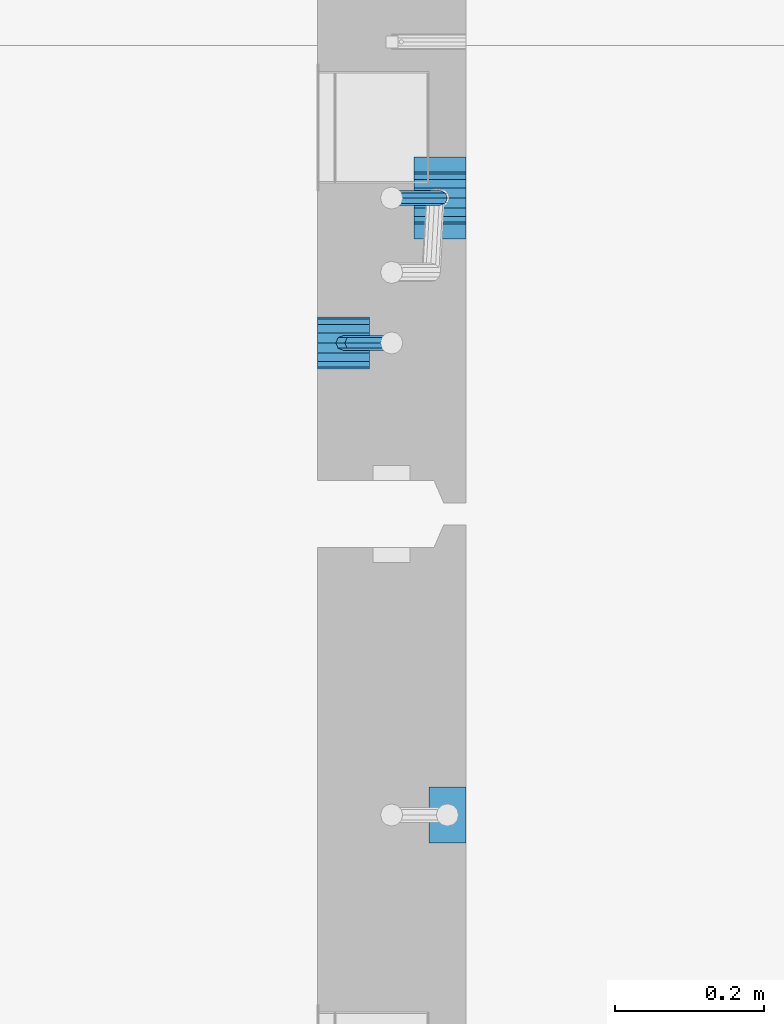
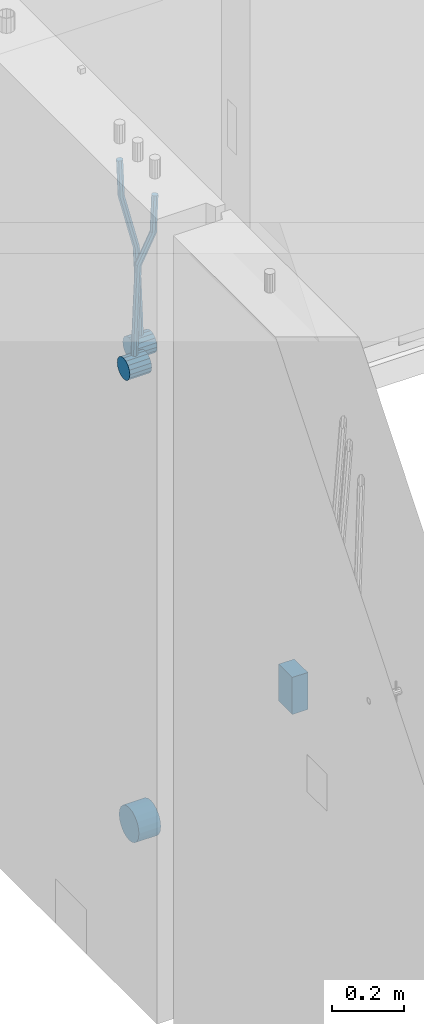
# One storey, part 147 of 352: 6 beams, 2 elements without a shape of their own.
"""IFC2X3 building model written with IfcOpenShell, lengths in millimetres."""

from ifc_helpers import new_model, si_unit, frame, origin_with_axes, place, context, subcontext, project, spatial, faceted_brep, material, type_object, element, aggregate, save


model = new_model("IFC2X3")

# Units and contexts
model_context = context("Model", 3, precision=1e-05, world=origin_with_axes())
body_context = subcontext(model_context, "Body", "Model", "MODEL_VIEW")
ifc_project = project(units=[si_unit("LENGTHUNIT", "METRE", prefix="MILLI"), si_unit("AREAUNIT", "SQUARE_METRE"), si_unit("VOLUMEUNIT", "CUBIC_METRE"), si_unit("MASSUNIT", "GRAM", prefix="KILO"), si_unit("TIMEUNIT", "SECOND"), si_unit("PLANEANGLEUNIT", "RADIAN"), si_unit("SOLIDANGLEUNIT", "STERADIAN"), si_unit("THERMODYNAMICTEMPERATUREUNIT", "DEGREE_CELSIUS"), si_unit("LUMINOUSINTENSITYUNIT", "LUMEN")], contexts=[model_context])

# Site, building, storey
site_placement = place(None, origin_with_axes())
site = spatial("IfcSite", under=ifc_project, at=site_placement, CompositionType="ELEMENT")
building_placement = place(site_placement, origin_with_axes())
building = spatial("IfcBuilding", under=site, at=building_placement, CompositionType="ELEMENT")
storey_placement = place(building_placement, origin_with_axes())
storey = spatial("IfcBuildingStorey", under=building, at=storey_placement, Name="6", CompositionType="ELEMENT", Elevation=0.0)

# Assembly, beams
assembly_1_placement = place(storey_placement, origin_with_axes())
assembly_1 = element("IfcElementAssembly", 1, at=assembly_1_placement, inside=storey, AssemblyPlace="NOTDEFINED", PredefinedType="REINFORCEMENT_UNIT")
ifc_material = material()
beam_type_1 = type_object("IfcBeamType", Name="D20", PredefinedType="NOTDEFINED")
beam_1_placement = place(assembly_1_placement, frame((21875.0000022791, 12925.0000000039, 98795.0), z_axis=(-0.999642804636942, -0.000205726999925762, -0.0267249099902983), x_axis=(-0.0267249099948371, 4.30000201934385e-08, 0.999642825806181)))
beam_1 = element("IfcBeam", 2, at=beam_1_placement, type_object=beam_type_1, material=ifc_material, Name="JM20", ObjectType="D20", context=body_context, shape_type="Brep", body=[
    faceted_brep([(0.0, -10.0, 0.0), (-4.19531716033816e-08, -7.07106781186667, -7.07106781187031), (60.4266690400545, -7.0710677960451, -7.07106780570757), (60.4266690441291, -9.99999998418934, 6.15546014159918e-09), (0.0, 0.0, -10.0), (60.426669036824, 1.58106558956206e-08, -9.99999999384454), (4.196772351861e-08, 7.07106781186303, -7.07106781186667), (60.4266690363438, 7.07106782768096, -7.07106780570757), (0.0, 10.0, 0.0), (60.4266690388904, 10.0000000158179, 6.15182216279209e-09), (4.196772351861e-08, 7.07106781185939, 7.07106781185939), (60.4266690429649, 7.07106782768096, 7.07106781802577), (0.0, 0.0, 10.0), (60.4266690461809, 1.58179318532348e-08, 10.0000000061555), (-4.19531716033816e-08, -7.07106781187031, 7.07106781185939), (60.4266690466611, -7.07106779605238, 7.07106781802213), (61.0378400410118, -7.07106779588503, -7.07106780564936), (60.991799419251, -9.99999998403655, 6.21366780251265e-09), (61.0569027789461, 1.5985278878361e-08, -9.99999999378269), (61.0378209396877, 7.07106782784831, -7.07106780564936), (60.9917724058905, 10.0000000159635, 6.21366780251265e-09), (60.9457317841297, 7.07106782781193, 7.0710678180767), (60.9266690461809, 1.59488990902901e-08, 10.0000000062028), (60.9457508854539, -7.07106779591413, 7.0710678180767), (61.6489592143771, -7.07106614513759, -7.06310863441468), (61.5568818710308, -9.9999984576425, 0.00735959856683621), (61.6870830769039, 1.71821739058942e-06, -9.99179257185824), (61.6489210170112, 7.07106947854481, -7.06310888312146), (61.556827851804, 10.0000015422847, 0.00735924683976918), (61.4647505084577, 7.07106922979438, 7.07782747982128), (61.4266266459163, 1.36643211590126e-06, 10.0065114172685), (61.464788705809, -7.07106639389531, 7.07782772852806), (176.543135720174, -7.07075579406956, -5.56673531796696), (176.451058376813, -9.99968810657447, 1.50373291501455), (176.581259582701, 0.000312069292704109, -8.49541925541052), (176.543097522794, 7.07137982961285, -5.56673556667374), (176.451004357587, 10.00031189336, 1.50373256329476), (176.35892701424, 7.07137958085514, 8.57420079627263), (176.320803151699, 0.000311717507429421, 11.5028847337162), (176.358965211621, -7.07075604281999, 8.57420104497578), (177.098753836006, -7.07075429323595, -5.55949898843028), (176.98362511232, -9.99968666800123, 1.510669025065), (177.146421932586, 0.000313595905026887, -8.48805862247536), (177.098706077581, 7.07138133041735, -5.55949936166144), (176.983557571715, 10.0003133318824, 1.51066849724157), (176.868428848029, 7.07138095712435, 8.58083651073321), (176.820760751449, 0.000313067976094317, 11.5093961447819), (176.868476606425, -7.07075466652896, 8.58083688396073), (177.654312950661, -7.07075204110879, -5.54863964998367), (177.516135294456, -9.99968450931192, 1.52107783331303), (177.711524267797, 0.000315886711177882, -8.47701274570863), (177.654255632195, 7.07138358250813, -5.54864021007961), (177.516054233929, 10.0003154905207, 1.5210770412159), (177.377876577739, 7.0713830223176, 8.59079452451624), (177.320665260588, 0.000315094497636892, 11.5191676202448), (177.377933896176, -7.07075260129932, 8.59079508461218), (298.592214475648, -7.07025824167067, -3.18470470795364), (298.454036904819, -9.99919071054683, 3.88501277673276), (298.649425586758, 0.000809686429420253, -6.11307780703646), (298.592156745173, 7.07187738194261, -3.18470527475802), (298.453955261604, 10.0008092892858, 3.88501197515143), (298.315777690761, 7.07187682041331, 10.9547294598378), (298.258566579665, 0.000808892309578368, 13.883102558917), (298.31583542125, -7.07025880319998, 10.9547300266422), (300.829882012156, -7.07024910539985, -3.14096572775816), (299.972022738802, -9.99918451269514, 3.91468436611831), (301.18507173346, 0.000820039333120803, -6.0635143331092), (300.829526581147, 7.07188651699835, -3.14097211362241), (299.971520083447, 10.0008154854204, 3.91467533514515), (299.113660810108, 7.07188007812692, 10.9703254290253), (298.758471088819, 0.000810933392131119, 13.8928740343799), (299.114016241103, -7.07025554427128, 10.9703318148859), (303.012825988379, -7.0701468967527, -2.64717965084128), (301.452885279024, -9.99911517653163, 4.24965828764471), (303.65870706641, 0.000935858577577164, -5.50397331873319), (303.012180137302, 7.07198871204673, -2.64725173027909), (301.451971907663, 10.0008848023517, 4.24955635192964), (299.892031198324, 7.07191652257279, 11.1463942904193), (299.246150120278, 0.000833767242511385, 14.0031879583075), (299.892677049385, -7.07021908622846, 11.1464663698534), (490.480206458145, -7.06136939830685, 39.7582981627347), (488.920265748791, -9.9903376780876, 46.6551361012243), (491.126087536177, 0.00971335702342913, 36.9015044948464), (490.479560607055, 7.0807662104944, 39.7582260832969), (488.91935237743, 10.0096623007976, 46.6550341655056), (487.359411668076, 7.08069402101864, 53.5518721039953), (486.713530590045, 0.00961126568654436, 56.4086657718872), (487.360057519167, -7.06144158778261, 53.5519441834331), (491.222094319732, -7.06133466202664, 39.9261146072568), (490.367102775039, -9.9902699350514, 46.9824133868096), (491.613766567636, 0.0097361908719904, 37.0118184187741), (491.312683227967, 7.08080521851844, 39.9466800038063), (490.495214837676, 10.0097360849959, 47.0114972495248), (489.640223292983, 7.08080081197113, 54.0677960290814), (489.248551045079, 0.00972995907250152, 56.9820922175604), (489.549634384748, -7.06133906857212, 54.0472306325282), (491.98259360576, -7.07125184727738, 39.9362361015701), (491.850235984879, -10.009610527557, 47.0021524248696), (492.113679795017, 0.00321714190249622, 37.0184717700395), (492.166706040836, 7.06966845271199, 39.958046203883), (492.110610287549, 9.988670745126, 47.0329965673554), (491.978252666668, 7.05031206484455, 54.0989128906476), (491.847166477397, -0.0241569243353297, 57.0166772221819), (491.794140231592, -7.09060823514483, 54.077102788342), (512.839684553823, -7.34323584322192, 40.2138233804726), (512.707326932941, -10.2815945235034, 47.2797397037684), (512.970770743079, -0.268766854042042, 37.296059048942), (513.023796988884, 6.79768445676746, 40.2356334827819), (512.967701235597, 9.71668674918146, 47.3105838462543), (512.83534361473, 6.77832806890183, 54.3765001695538), (512.704257425459, -0.296140920279868, 57.2942645010808), (512.651231179654, -7.36259223108937, 54.3546900672372), (513.475042066755, -7.35152113457298, 40.2222793613946), (513.367413171509, -10.2902022863618, 47.2885247996019), (513.548971693657, -0.276306803183616, 37.3037543324754), (513.545895079456, 6.79087610917486, 40.2425820926655), (513.467614462992, 9.71016770021379, 47.3172371975234), (513.359985567746, 6.77148654842495, 54.3834826357306), (513.286055940844, -0.303727782968053, 57.3020076646499), (513.289132555044, -7.37091069532653, 54.3631799044524), (514.110453382629, -7.34964673829199, 40.2305416874733), (514.027555144421, -10.2882337755309, 47.2971163788461), (514.127221878356, -0.274611275939606, 37.3112548247955), (514.06803787424, 6.7924127919523, 40.249334442502), (513.967570557215, 9.71165861202826, 47.3236933478729), (513.884672319007, 6.77307157479117, 54.3902680392421), (513.867903823266, -0.301963887563034, 57.3095549019235), (513.927087827382, -7.36898795545494, 54.3714752842207), (614.131240716772, -7.05138387012084, 41.5279197320488), (614.048342478563, -9.98997090735793, 48.5944944234179), (614.148009212484, 0.0236515922315448, 38.6086328693636), (614.088825208368, 7.09067566012527, 41.5467124870702), (613.988357891343, 10.0099214802012, 48.6210713924484), (613.905459653135, 7.07133444296232, 55.6876460838175), (613.888691157408, -0.00370101939006418, 58.606932946499), (613.947875161524, -7.07072508728379, 55.6688533287888)], [[[0, 1, 2, 3]], [[1, 4, 5, 2]], [[4, 6, 7, 5]], [[6, 8, 9, 7]], [[8, 10, 11, 9]], [[10, 12, 13, 11]], [[12, 14, 15, 13]], [[14, 0, 3, 15]], [[14, 12, 10, 8, 6, 4, 1, 0]], [[3, 2, 16, 17]], [[2, 5, 18, 16]], [[5, 7, 19, 18]], [[7, 9, 20, 19]], [[9, 11, 21, 20]], [[11, 13, 22, 21]], [[13, 15, 23, 22]], [[15, 3, 17, 23]], [[17, 16, 24, 25]], [[16, 18, 26, 24]], [[18, 19, 27, 26]], [[19, 20, 28, 27]], [[20, 21, 29, 28]], [[21, 22, 30, 29]], [[22, 23, 31, 30]], [[23, 17, 25, 31]], [[25, 24, 32, 33]], [[24, 26, 34, 32]], [[26, 27, 35, 34]], [[27, 28, 36, 35]], [[28, 29, 37, 36]], [[29, 30, 38, 37]], [[30, 31, 39, 38]], [[31, 25, 33, 39]], [[33, 32, 40, 41]], [[32, 34, 42, 40]], [[34, 35, 43, 42]], [[35, 36, 44, 43]], [[36, 37, 45, 44]], [[37, 38, 46, 45]], [[38, 39, 47, 46]], [[39, 33, 41, 47]], [[41, 40, 48, 49]], [[40, 42, 50, 48]], [[42, 43, 51, 50]], [[43, 44, 52, 51]], [[44, 45, 53, 52]], [[45, 46, 54, 53]], [[46, 47, 55, 54]], [[47, 41, 49, 55]], [[49, 48, 56, 57]], [[48, 50, 58, 56]], [[50, 51, 59, 58]], [[51, 52, 60, 59]], [[52, 53, 61, 60]], [[53, 54, 62, 61]], [[54, 55, 63, 62]], [[55, 49, 57, 63]], [[57, 56, 64, 65]], [[56, 58, 66, 64]], [[58, 59, 67, 66]], [[59, 60, 68, 67]], [[60, 61, 69, 68]], [[61, 62, 70, 69]], [[62, 63, 71, 70]], [[63, 57, 65, 71]], [[65, 64, 72, 73]], [[64, 66, 74, 72]], [[66, 67, 75, 74]], [[67, 68, 76, 75]], [[68, 69, 77, 76]], [[69, 70, 78, 77]], [[70, 71, 79, 78]], [[71, 65, 73, 79]], [[73, 72, 80, 81]], [[72, 74, 82, 80]], [[74, 75, 83, 82]], [[75, 76, 84, 83]], [[76, 77, 85, 84]], [[77, 78, 86, 85]], [[78, 79, 87, 86]], [[79, 73, 81, 87]], [[81, 80, 88, 89]], [[80, 82, 90, 88]], [[82, 83, 91, 90]], [[83, 84, 92, 91]], [[84, 85, 93, 92]], [[85, 86, 94, 93]], [[86, 87, 95, 94]], [[87, 81, 89, 95]], [[89, 88, 96, 97]], [[88, 90, 98, 96]], [[90, 91, 99, 98]], [[91, 92, 100, 99]], [[92, 93, 101, 100]], [[93, 94, 102, 101]], [[94, 95, 103, 102]], [[95, 89, 97, 103]], [[97, 96, 104, 105]], [[96, 98, 106, 104]], [[98, 99, 107, 106]], [[99, 100, 108, 107]], [[100, 101, 109, 108]], [[101, 102, 110, 109]], [[102, 103, 111, 110]], [[103, 97, 105, 111]], [[105, 104, 112, 113]], [[104, 106, 114, 112]], [[106, 107, 115, 114]], [[107, 108, 116, 115]], [[108, 109, 117, 116]], [[109, 110, 118, 117]], [[110, 111, 119, 118]], [[111, 105, 113, 119]], [[113, 112, 120, 121]], [[112, 114, 122, 120]], [[114, 115, 123, 122]], [[115, 116, 124, 123]], [[116, 117, 125, 124]], [[117, 118, 126, 125]], [[118, 119, 127, 126]], [[119, 113, 121, 127]], [[121, 120, 128, 129]], [[120, 122, 130, 128]], [[122, 123, 131, 130]], [[123, 124, 132, 131]], [[124, 125, 133, 132]], [[125, 126, 134, 133]], [[126, 127, 135, 134]], [[127, 121, 129, 135]], [[130, 131, 132, 133, 134, 135, 129, 128]]]),
])
beam_2_placement = place(assembly_1_placement, frame((21744.9999977209, 12729.9999999961, 98890.0), z_axis=(0.999642804629538, 0.000205762999925497, -0.0267249099901003), x_axis=(0.0267249109941254, -4.30000210532798e-08, 0.999642825779465)))
beam_2 = element("IfcBeam", 3, at=beam_2_placement, type_object=beam_type_1, material=ifc_material, Name="JM20", ObjectType="D20", context=body_context, shape_type="Brep", body=[
    faceted_brep([(0.0, -10.0, 0.0), (-4.19531716033816e-08, -7.07106781186667, -7.07106781187031), (60.4266690400545, -7.0710677960451, -7.07106780570757), (60.4266690441291, -9.99999998418934, 6.15546014159918e-09), (0.0, 0.0, -10.0), (60.426669036824, 1.58106558956206e-08, -9.99999999384454), (4.196772351861e-08, 7.07106781186303, -7.07106781186667), (60.4266690363438, 7.07106782768096, -7.07106780570757), (0.0, 10.0, 0.0), (60.4266690388904, 10.0000000158179, 6.15182216279209e-09), (4.196772351861e-08, 7.07106781185939, 7.07106781185939), (60.4266690429649, 7.07106782768096, 7.07106781802577), (0.0, 0.0, 10.0), (60.4266690461809, 1.58179318532348e-08, 10.0000000061555), (-4.19531716033816e-08, -7.07106781187031, 7.07106781185939), (60.4266690466611, -7.07106779605238, 7.07106781802213), (61.0378400410118, -7.07106779588503, -7.07106780564936), (60.991799419251, -9.99999998403655, 6.21366780251265e-09), (61.0569027789461, 1.5985278878361e-08, -9.99999999378269), (61.0378209396877, 7.07106782784831, -7.07106780564936), (60.9917724058905, 10.0000000159635, 6.21366780251265e-09), (60.9457317841297, 7.07106782781193, 7.0710678180767), (60.9266690461809, 1.59488990902901e-08, 10.0000000062028), (60.9457508854539, -7.07106779591413, 7.0710678180767), (61.6489592143771, -7.07106614513759, -7.06310863441468), (61.5568818710308, -9.9999984576425, 0.00735959856683621), (61.6870830769039, 1.71821739058942e-06, -9.99179257185824), (61.6489210170112, 7.07106947854481, -7.06310888312146), (61.556827851804, 10.0000015422847, 0.00735924683976918), (61.4647505084577, 7.07106922979438, 7.07782747982128), (61.4266266459163, 1.36643211590126e-06, 10.0065114172685), (61.464788705809, -7.07106639389531, 7.07782772852806), (176.543135720174, -7.07075579406956, -5.56673531796696), (176.451058376813, -9.99968810657447, 1.50373291501455), (176.581259582701, 0.000312069292704109, -8.49541925541052), (176.543097522794, 7.07137982961285, -5.56673556667374), (176.451004357587, 10.00031189336, 1.50373256329476), (176.35892701424, 7.07137958085514, 8.57420079627263), (176.320803151699, 0.000311717507429421, 11.5028847337162), (176.358965211621, -7.07075604281999, 8.57420104497578), (177.098753836006, -7.07075429323595, -5.55949898843028), (176.98362511232, -9.99968666800123, 1.510669025065), (177.146421932586, 0.000313595905026887, -8.48805862247536), (177.098706077581, 7.07138133041735, -5.55949936166144), (176.983557571715, 10.0003133318824, 1.51066849724157), (176.868428848029, 7.07138095712435, 8.58083651073321), (176.820760751449, 0.000313067976094317, 11.5093961447819), (176.868476606425, -7.07075466652896, 8.58083688396073), (177.654312950661, -7.07075204110879, -5.54863964998367), (177.516135294456, -9.99968450931192, 1.52107783331303), (177.711524267797, 0.000315886711177882, -8.47701274570863), (177.654255632195, 7.07138358250813, -5.54864021007961), (177.516054233929, 10.0003154905207, 1.5210770412159), (177.377876577739, 7.0713830223176, 8.59079452451624), (177.320665260588, 0.000315094497636892, 11.5191676202448), (177.377933896176, -7.07075260129932, 8.59079508461218), (297.446964549832, -7.07026642590426, -3.20709054437975), (297.308786893627, -9.99919889410376, 3.86262693891331), (297.504175866998, 0.000801501919340808, -6.13546364010836), (297.44690723141, 7.07186919770902, -3.20709110447569), (297.308705833115, 10.0008011057289, 3.86262614682164), (297.170528176895, 7.07186863752577, 10.9323436301165), (297.113316859759, 0.000800709702161839, 13.8607167258415), (297.170585495318, -7.07026698608752, 10.9323441902106), (301.63986343499, -7.07024942873613, -3.12513327486886), (299.972259732356, -9.99918809692099, 3.91468900081236), (302.330321453323, 0.000821066147182137, -6.04112849743797), (301.639172844472, 7.07188619231601, -3.12514621333321), (299.971283089879, 10.0008118992846, 3.91467070306135), (298.303679387245, 7.07187323109611, 10.9544929787371), (297.613221368898, 0.000802736216428457, 13.870488201308), (298.304369977734, -7.0702623899524, 10.9545059172033), (305.4239078393, -7.06987516590743, -1.31733741553398), (302.376014215231, -9.99895035236841, 5.06306278734701), (306.685863931343, 0.00125185327851796, -3.96030416885333), (305.422645727784, 7.07226039861052, -1.31762339341367), (302.374229320019, 10.0010495638962, 5.06265835355225), (299.326335695951, 7.07197437743162, 11.4430585564332), (298.064379603893, 0.000847358245664509, 14.0860253097508), (299.327597807453, -7.07016118708634, 11.4433445343111), (396.081143409523, -7.0609086662007, 41.9934056867296), (393.033249785469, -9.98998385266168, 48.3738058896106), (397.34309950161, 0.0102183529888862, 39.3504389334103), (396.079881298036, 7.08122689832453, 41.9931197088481), (393.031464890271, 10.0100160636066, 48.3734014558122), (389.983571266188, 7.08094087714562, 54.753801658695), (388.72161517413, 0.00981385795967071, 57.3967684120162), (389.984833377704, -7.06119468737961, 54.7540876365765), (397.068790959223, -7.06081098241702, 42.4652461198857), (395.403898118791, -9.98974938248648, 49.5063634875187), (397.79425773659, 0.0102629750217602, 39.565976041853), (397.155329851754, 7.08133326610914, 42.5069063441551), (395.526282594277, 10.0102628148125, 49.5652799416912), (393.861389753831, 7.08132441474299, 56.606397309326), (393.135922976478, 0.0102504573078477, 59.5056673873569), (393.774850861315, -7.06081983378317, 56.5647370850584), (398.163169908337, -7.0750819080713, 42.4798112226927), (398.030733605352, -10.0240038552729, 49.541324073105), (398.294170965004, 0.00374400413056719, 39.572629393122), (398.346998133013, 7.06579366763617, 42.5227662718698), (398.290705973835, 9.97421416771613, 49.6020716862276), (398.15826967085, 7.02529222051089, 56.6635845366436), (398.027268614198, -0.0535336916836968, 59.5707663662142), (397.974441446175, -7.11558335519294, 56.6206294874646), (417.87389934808, -7.33211385723553, 42.7421415616409), (417.741463045095, -10.2810358044335, 49.803654412055), (418.004900404732, -0.253287945030024, 39.8349597320685), (418.057727572756, 6.8087617184683, 42.7850966108181), (418.001435413564, 9.71718221855917, 49.8644020251777), (417.868999110593, 6.76826027135394, 56.92591487559), (417.737998053926, -0.310565640847926, 59.8330967051625), (417.685170885918, -7.37261530435353, 56.8829598264128), (418.509166047603, -7.3403978651113, 42.7505963339045), (418.401542092906, -10.2896433704191, 49.812439412166), (418.582978010687, -0.260826195415575, 39.8426533739894), (418.579739935274, 6.80195457034279, 42.7920440797316), (418.501348641992, 9.71066324766434, 49.8710553764413), (418.393724687281, 6.76141774235657, 56.9328984547028), (418.319912724211, -0.318153927339154, 59.8408414146197), (418.323150799639, -7.38093469310479, 56.8914507088775), (419.144486528079, -7.33852513420788, 42.7588588031304), (419.061676848418, -10.2876749343814, 49.821032815089), (419.161104845465, -0.25913295731516, 39.8501522177412), (419.101797015624, 6.80348967242753, 42.7987939276718), (419.00130476091, 9.71215420445515, 49.8775096098252), (418.918495081249, 6.76300440428531, 56.9396836217802), (418.901876763863, -0.316387772607413, 59.8483902071712), (418.961184593718, -7.37901040236102, 56.8997484972406), (519.165277458538, -7.04026297675227, 44.0562368946885), (519.082467778877, -9.98941277692575, 51.1184109066417), (519.181895775939, 0.0391292001404508, 41.1475303092957), (519.122587946098, 7.10175182989406, 44.0961720192245), (519.022095691384, 10.0104163619108, 51.1748877013797), (518.939286011722, 7.06126656174456, 58.2370617133347), (518.922667694336, -0.0181256151481648, 61.1457682987275), (518.981975524162, -7.08074824490541, 58.1971265887951)], [[[0, 1, 2, 3]], [[1, 4, 5, 2]], [[4, 6, 7, 5]], [[6, 8, 9, 7]], [[8, 10, 11, 9]], [[10, 12, 13, 11]], [[12, 14, 15, 13]], [[14, 0, 3, 15]], [[14, 12, 10, 8, 6, 4, 1, 0]], [[3, 2, 16, 17]], [[2, 5, 18, 16]], [[5, 7, 19, 18]], [[7, 9, 20, 19]], [[9, 11, 21, 20]], [[11, 13, 22, 21]], [[13, 15, 23, 22]], [[15, 3, 17, 23]], [[17, 16, 24, 25]], [[16, 18, 26, 24]], [[18, 19, 27, 26]], [[19, 20, 28, 27]], [[20, 21, 29, 28]], [[21, 22, 30, 29]], [[22, 23, 31, 30]], [[23, 17, 25, 31]], [[25, 24, 32, 33]], [[24, 26, 34, 32]], [[26, 27, 35, 34]], [[27, 28, 36, 35]], [[28, 29, 37, 36]], [[29, 30, 38, 37]], [[30, 31, 39, 38]], [[31, 25, 33, 39]], [[33, 32, 40, 41]], [[32, 34, 42, 40]], [[34, 35, 43, 42]], [[35, 36, 44, 43]], [[36, 37, 45, 44]], [[37, 38, 46, 45]], [[38, 39, 47, 46]], [[39, 33, 41, 47]], [[41, 40, 48, 49]], [[40, 42, 50, 48]], [[42, 43, 51, 50]], [[43, 44, 52, 51]], [[44, 45, 53, 52]], [[45, 46, 54, 53]], [[46, 47, 55, 54]], [[47, 41, 49, 55]], [[49, 48, 56, 57]], [[48, 50, 58, 56]], [[50, 51, 59, 58]], [[51, 52, 60, 59]], [[52, 53, 61, 60]], [[53, 54, 62, 61]], [[54, 55, 63, 62]], [[55, 49, 57, 63]], [[57, 56, 64, 65]], [[56, 58, 66, 64]], [[58, 59, 67, 66]], [[59, 60, 68, 67]], [[60, 61, 69, 68]], [[61, 62, 70, 69]], [[62, 63, 71, 70]], [[63, 57, 65, 71]], [[65, 64, 72, 73]], [[64, 66, 74, 72]], [[66, 67, 75, 74]], [[67, 68, 76, 75]], [[68, 69, 77, 76]], [[69, 70, 78, 77]], [[70, 71, 79, 78]], [[71, 65, 73, 79]], [[73, 72, 80, 81]], [[72, 74, 82, 80]], [[74, 75, 83, 82]], [[75, 76, 84, 83]], [[76, 77, 85, 84]], [[77, 78, 86, 85]], [[78, 79, 87, 86]], [[79, 73, 81, 87]], [[81, 80, 88, 89]], [[80, 82, 90, 88]], [[82, 83, 91, 90]], [[83, 84, 92, 91]], [[84, 85, 93, 92]], [[85, 86, 94, 93]], [[86, 87, 95, 94]], [[87, 81, 89, 95]], [[89, 88, 96, 97]], [[88, 90, 98, 96]], [[90, 91, 99, 98]], [[91, 92, 100, 99]], [[92, 93, 101, 100]], [[93, 94, 102, 101]], [[94, 95, 103, 102]], [[95, 89, 97, 103]], [[97, 96, 104, 105]], [[96, 98, 106, 104]], [[98, 99, 107, 106]], [[99, 100, 108, 107]], [[100, 101, 109, 108]], [[101, 102, 110, 109]], [[102, 103, 111, 110]], [[103, 97, 105, 111]], [[105, 104, 112, 113]], [[104, 106, 114, 112]], [[106, 107, 115, 114]], [[107, 108, 116, 115]], [[108, 109, 117, 116]], [[109, 110, 118, 117]], [[110, 111, 119, 118]], [[111, 105, 113, 119]], [[113, 112, 120, 121]], [[112, 114, 122, 120]], [[114, 115, 123, 122]], [[115, 116, 124, 123]], [[116, 117, 125, 124]], [[117, 118, 126, 125]], [[118, 119, 127, 126]], [[119, 113, 121, 127]], [[121, 120, 128, 129]], [[120, 122, 130, 128]], [[122, 123, 131, 130]], [[123, 124, 132, 131]], [[124, 125, 133, 132]], [[125, 126, 134, 133]], [[126, 127, 135, 134]], [[127, 121, 129, 135]], [[130, 131, 132, 133, 134, 135, 129, 128]]]),
])
beam_type_2 = type_object("IfcBeamType", Name="D70", PredefinedType="NOTDEFINED")
beam_3_placement = place(assembly_1_placement, frame((21839.9999977209, 12925.0, 98760.0), z_axis=(0.0, 0.0, 1.0), x_axis=(1.0, 0.0, 0.0)))
beam_3 = element("IfcBeam", 4, at=beam_3_placement, type_object=beam_type_2, material=ifc_material, ObjectType="D70", context=body_context, shape_type="Brep", body=[
    faceted_brep([(0.0, -35.0, 0.0), (0.0, -32.3357836378964, -13.3939201327739), (70.0, -32.3357836378964, -13.3939201327739), (70.0, -35.0, 0.0), (0.0, -24.7487373415279, -24.7487373415352), (70.0, -24.7487373415279, -24.7487373415352), (0.0, -13.3939201327776, -32.3357836379), (70.0, -13.3939201327776, -32.3357836379), (0.0, 0.0, -35.0), (70.0, 0.0, -35.0), (0.0, 13.3939201327776, -32.3357836379), (70.0, 13.3939201327776, -32.3357836379), (0.0, 24.7487373415279, -24.7487373415352), (70.0, 24.7487373415279, -24.7487373415352), (0.0, 32.3357836378964, -13.3939201327739), (70.0, 32.3357836378964, -13.3939201327739), (0.0, 35.0, 0.0), (70.0, 35.0, 0.0), (0.0, 32.3357836378964, 13.3939201327739), (70.0, 32.3357836378964, 13.3939201327739), (0.0, 24.7487373415279, 24.7487373415352), (70.0, 24.7487373415279, 24.7487373415352), (0.0, 13.3939201327776, 32.3357836379), (70.0, 13.3939201327776, 32.3357836379), (0.0, 0.0, 35.0), (70.0, 0.0, 35.0), (0.0, -13.3939201327776, 32.3357836379), (70.0, -13.3939201327776, 32.3357836379), (0.0, -24.7487373415279, 24.7487373415352), (70.0, -24.7487373415279, 24.7487373415352), (0.0, -32.3357836378964, 13.3939201327739), (70.0, -32.3357836378964, 13.3939201327739)], [[[0, 1, 2, 3]], [[1, 4, 5, 2]], [[4, 6, 7, 5]], [[6, 8, 9, 7]], [[8, 10, 11, 9]], [[10, 12, 13, 11]], [[12, 14, 15, 13]], [[14, 16, 17, 15]], [[16, 18, 19, 17]], [[18, 20, 21, 19]], [[20, 22, 23, 21]], [[22, 24, 25, 23]], [[24, 26, 27, 25]], [[26, 28, 29, 27]], [[28, 30, 31, 29]], [[30, 0, 3, 31]], [[5, 7, 9, 11, 13, 15, 17, 19, 21, 23, 25, 27, 29, 31, 3, 2]], [[30, 28, 26, 24, 22, 20, 18, 16, 14, 12, 10, 8, 6, 4, 1, 0]]]),
])
beam_4_placement = place(assembly_1_placement, frame((21709.9999977209, 12730.0, 98855.0), z_axis=(0.0, 0.0, 1.0), x_axis=(1.0, 0.0, 0.0)))
beam_4 = element("IfcBeam", 5, at=beam_4_placement, type_object=beam_type_2, material=ifc_material, ObjectType="D70", context=body_context, shape_type="Brep", body=[
    faceted_brep([(0.0, -35.0, 0.0), (0.0, -32.3357836378964, -13.3939201327739), (70.0, -32.3357836378964, -13.3939201327739), (70.0, -35.0, 0.0), (0.0, -24.7487373415279, -24.7487373415352), (70.0, -24.7487373415279, -24.7487373415352), (0.0, -13.3939201327776, -32.3357836379), (70.0, -13.3939201327776, -32.3357836379), (0.0, 0.0, -35.0), (70.0, 0.0, -35.0), (0.0, 13.3939201327776, -32.3357836379), (70.0, 13.3939201327776, -32.3357836379), (0.0, 24.7487373415279, -24.7487373415352), (70.0, 24.7487373415279, -24.7487373415352), (0.0, 32.3357836378964, -13.3939201327739), (70.0, 32.3357836378964, -13.3939201327739), (0.0, 35.0, 0.0), (70.0, 35.0, 0.0), (0.0, 32.3357836378964, 13.3939201327739), (70.0, 32.3357836378964, 13.3939201327739), (0.0, 24.7487373415279, 24.7487373415352), (70.0, 24.7487373415279, 24.7487373415352), (0.0, 13.3939201327776, 32.3357836379), (70.0, 13.3939201327776, 32.3357836379), (0.0, 0.0, 35.0), (70.0, 0.0, 35.0), (0.0, -13.3939201327776, 32.3357836379), (70.0, -13.3939201327776, 32.3357836379), (0.0, -24.7487373415279, 24.7487373415352), (70.0, -24.7487373415279, 24.7487373415352), (0.0, -32.3357836378964, 13.3939201327739), (70.0, -32.3357836378964, 13.3939201327739)], [[[0, 1, 2, 3]], [[1, 4, 5, 2]], [[4, 6, 7, 5]], [[6, 8, 9, 7]], [[8, 10, 11, 9]], [[10, 12, 13, 11]], [[12, 14, 15, 13]], [[14, 16, 17, 15]], [[16, 18, 19, 17]], [[18, 20, 21, 19]], [[20, 22, 23, 21]], [[22, 24, 25, 23]], [[24, 26, 27, 25]], [[26, 28, 29, 27]], [[28, 30, 31, 29]], [[30, 0, 3, 31]], [[5, 7, 9, 11, 13, 15, 17, 19, 21, 23, 25, 27, 29, 31, 3, 2]], [[30, 28, 26, 24, 22, 20, 18, 16, 14, 12, 10, 8, 6, 4, 1, 0]]]),
])
beam_type_3 = type_object("IfcBeamType", Name="D110", PredefinedType="NOTDEFINED")
beam_5_placement = place(assembly_1_placement, frame((21910.0000022791, 12925.0, 97155.0), z_axis=(0.0, 0.0, 1.0), x_axis=(-1.0, 3.00000001838171e-08, 0.0)))
beam_5 = element("IfcBeam", 6, at=beam_5_placement, type_object=beam_type_3, material=ifc_material, ObjectType="D110", context=body_context, shape_type="Brep", body=[
    faceted_brep([(0.0, -55.0, 0.0), (0.0, -52.3081083962352, -16.9959346906253), (70.0, -52.3081083962352, -16.9959346906253), (70.0, -55.0, 0.0), (0.0, -44.4959346906217, -32.328188876083), (70.0, -44.4959346906217, -32.328188876083), (0.0, -32.3281888760866, -44.4959346906253), (70.0, -32.3281888760866, -44.4959346906253), (0.0, -16.9959346906217, -52.3081083962315), (70.0, -16.9959346906217, -52.3081083962315), (0.0, 0.0, -55.0), (70.0, 0.0, -55.0), (0.0, 16.9959346906217, -52.3081083962315), (70.0, 16.9959346906217, -52.3081083962315), (0.0, 32.3281888760866, -44.4959346906253), (70.0, 32.3281888760866, -44.4959346906253), (0.0, 44.4959346906217, -32.328188876083), (70.0, 44.4959346906217, -32.328188876083), (0.0, 52.3081083962352, -16.9959346906253), (70.0, 52.3081083962352, -16.9959346906253), (0.0, 55.0, 0.0), (70.0, 55.0, 0.0), (0.0, 52.3081083962352, 16.9959346906253), (70.0, 52.3081083962352, 16.9959346906253), (0.0, 44.4959346906217, 32.328188876083), (70.0, 44.4959346906217, 32.328188876083), (0.0, 32.3281888760866, 44.4959346906253), (70.0, 32.3281888760866, 44.4959346906253), (0.0, 16.9959346906217, 52.3081083962315), (70.0, 16.9959346906217, 52.3081083962315), (0.0, 0.0, 55.0), (70.0, 0.0, 55.0), (0.0, -16.9959346906217, 52.3081083962315), (70.0, -16.9959346906217, 52.3081083962315), (0.0, -32.3281888760866, 44.4959346906253), (70.0, -32.3281888760866, 44.4959346906253), (0.0, -44.4959346906217, 32.328188876083), (70.0, -44.4959346906217, 32.328188876083), (0.0, -52.3081083962352, 16.9959346906253), (70.0, -52.3081083962352, 16.9959346906253)], [[[0, 1, 2, 3]], [[1, 4, 5, 2]], [[4, 6, 7, 5]], [[6, 8, 9, 7]], [[8, 10, 11, 9]], [[10, 12, 13, 11]], [[12, 14, 15, 13]], [[14, 16, 17, 15]], [[16, 18, 19, 17]], [[18, 20, 21, 19]], [[20, 22, 23, 21]], [[22, 24, 25, 23]], [[24, 26, 27, 25]], [[26, 28, 29, 27]], [[28, 30, 31, 29]], [[30, 32, 33, 31]], [[32, 34, 35, 33]], [[34, 36, 37, 35]], [[36, 38, 39, 37]], [[38, 0, 3, 39]], [[5, 7, 9, 11, 13, 15, 17, 19, 21, 23, 25, 27, 29, 31, 33, 35, 37, 39, 3, 2]], [[38, 36, 34, 32, 30, 28, 26, 24, 22, 20, 18, 16, 14, 12, 10, 8, 6, 4, 1, 0]]]),
])
aggregate(assembly_1, [beam_1, beam_3, beam_2, beam_4, beam_5])

# Assembly, beam
assembly_2_placement = place(storey_placement, origin_with_axes())
assembly_2 = element("IfcElementAssembly", 7, at=assembly_2_placement, inside=storey, AssemblyPlace="NOTDEFINED", PredefinedType="REINFORCEMENT_UNIT")
beam_type_4 = type_object("IfcBeamType", Name="125X50", PredefinedType="NOTDEFINED")
beam_6_placement = place(assembly_2_placement, frame((21885.0, 12057.5, 98105.0), z_axis=(0.0, 0.0, 1.0), x_axis=(0.0, 1.0, 0.0)))
beam_6 = element("IfcBeam", 8, at=beam_6_placement, type_object=beam_type_4, material=ifc_material, Name="WM1", ObjectType="125X50", context=body_context, shape_type="Brep", body=[
    faceted_brep([(0.0, 25.0, -62.5), (0.0, 25.0, 62.5), (75.0, 25.0, 62.5), (75.0, 25.0, -62.5), (0.0, -25.0, 62.5), (75.0, -25.0, 62.5), (0.0, -25.0, -62.5), (75.0, -25.0, -62.5)], [[[0, 1, 2, 3]], [[1, 4, 5, 2]], [[4, 6, 7, 5]], [[6, 0, 3, 7]], [[5, 7, 3, 2]], [[0, 6, 4, 1]]]),
])
aggregate(assembly_2, [beam_6])

save(model, "model.ifc")
